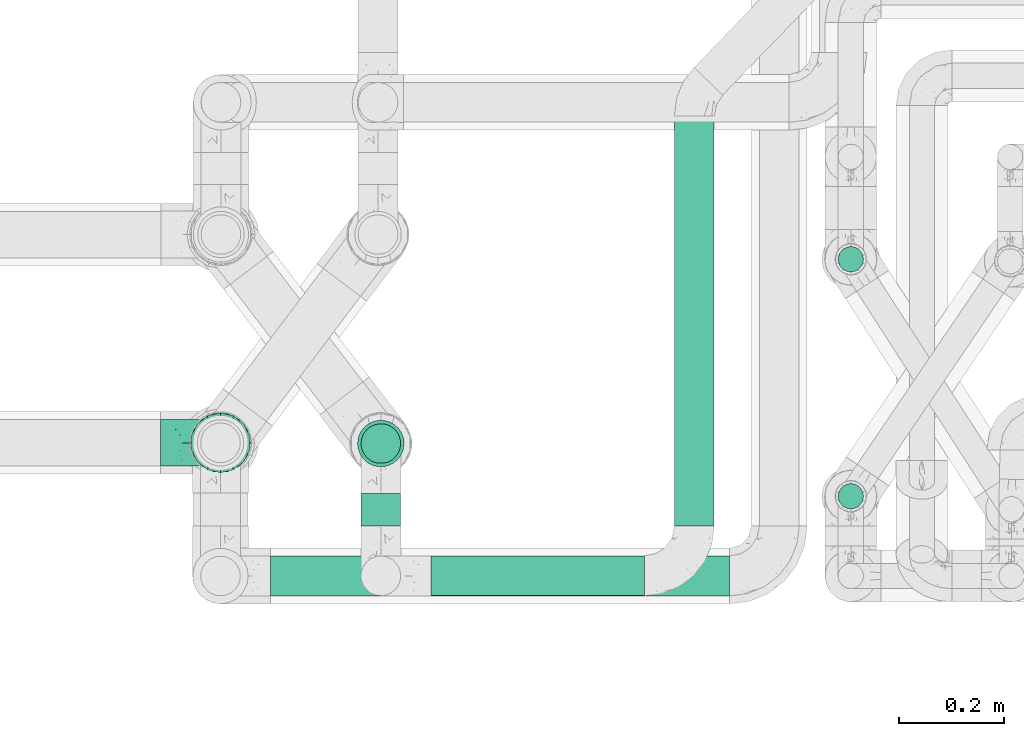
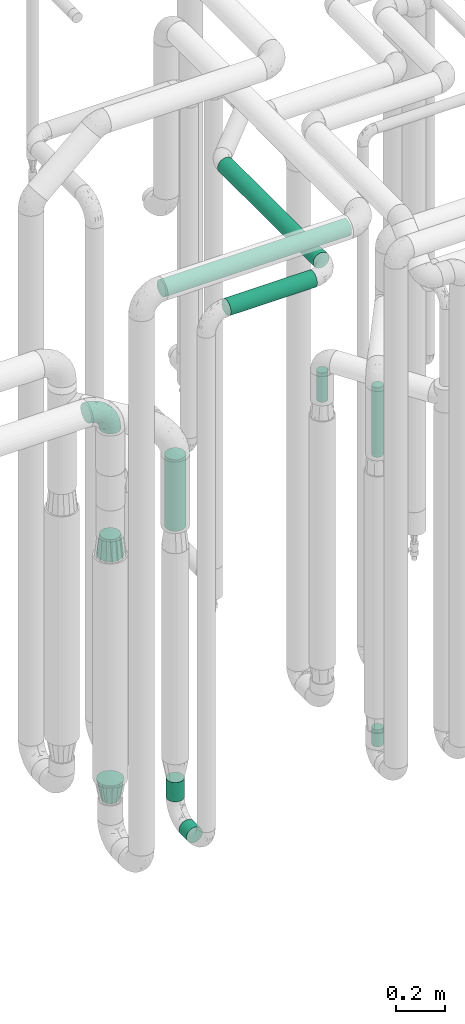
# One storey, part 659 of 827: 9 flow segments, 3 flow fittings.
"""IFC2X3 building model written with IfcOpenShell, lengths in millimetres."""

from ifc_helpers import new_model, entity, si_unit, converted_unit, derived_unit, direction, frame, origin, origin_2d_with_axis, place, context, subcontext, project, spatial, circle, extrude, faceted_brep, source, transform, mapped, material, type_object, type_shapes, element, save


model = new_model("IFC2X3")

# Units and contexts
model_context = context("Model", 3, precision=0.01, world=origin(), true_north=direction((6.12303176911189e-17, 1.0)))
body_context = subcontext(model_context, "Body", "Model", "MODEL_VIEW")
ifc_project = project(units=[si_unit("LENGTHUNIT", "METRE", prefix="MILLI"), si_unit("AREAUNIT", "SQUARE_METRE"), si_unit("VOLUMEUNIT", "CUBIC_METRE"), converted_unit("PLANEANGLEUNIT", "DEGREE", entity("IfcRatioMeasure", 0.0174532925199433), si_unit("PLANEANGLEUNIT", "RADIAN"), dimensions=[0, 0, 0, 0, 0, 0, 0]), si_unit("MASSUNIT", "GRAM", prefix="KILO"), derived_unit("MASSDENSITYUNIT", [(si_unit("MASSUNIT", "GRAM", prefix="KILO"), 1), (si_unit("LENGTHUNIT", "METRE"), -3)]), derived_unit("MOMENTOFINERTIAUNIT", [(si_unit("LENGTHUNIT", "METRE"), 4)]), si_unit("TIMEUNIT", "SECOND"), si_unit("FREQUENCYUNIT", "HERTZ"), si_unit("THERMODYNAMICTEMPERATUREUNIT", "DEGREE_CELSIUS"), derived_unit("THERMALTRANSMITTANCEUNIT", [(si_unit("MASSUNIT", "GRAM", prefix="KILO"), 1), (si_unit("THERMODYNAMICTEMPERATUREUNIT", "KELVIN"), -1), (si_unit("TIMEUNIT", "SECOND"), -3)]), derived_unit("VOLUMETRICFLOWRATEUNIT", [(si_unit("LENGTHUNIT", "METRE"), 3), (si_unit("TIMEUNIT", "SECOND"), -1)]), derived_unit("MASSFLOWRATEUNIT", [(si_unit("MASSUNIT", "GRAM", prefix="KILO"), 1), (si_unit("TIMEUNIT", "SECOND"), -1)]), derived_unit("ROTATIONALFREQUENCYUNIT", [(si_unit("TIMEUNIT", "SECOND"), -1)]), si_unit("ELECTRICCURRENTUNIT", "AMPERE"), si_unit("ELECTRICVOLTAGEUNIT", "VOLT"), si_unit("POWERUNIT", "WATT"), si_unit("FORCEUNIT", "NEWTON", prefix="KILO"), si_unit("ILLUMINANCEUNIT", "LUX"), si_unit("LUMINOUSFLUXUNIT", "LUMEN"), si_unit("LUMINOUSINTENSITYUNIT", "CANDELA"), derived_unit("USERDEFINED", [(si_unit("MASSUNIT", "GRAM", prefix="KILO"), -1), (si_unit("LENGTHUNIT", "METRE"), -2), (si_unit("TIMEUNIT", "SECOND"), 3), (si_unit("LUMINOUSFLUXUNIT", "LUMEN"), 1)]), derived_unit("LINEARVELOCITYUNIT", [(si_unit("LENGTHUNIT", "METRE"), 1), (si_unit("TIMEUNIT", "SECOND"), -1)]), si_unit("PRESSUREUNIT", "PASCAL"), derived_unit("USERDEFINED", [(si_unit("LENGTHUNIT", "METRE"), -2), (si_unit("MASSUNIT", "GRAM", prefix="KILO"), 1), (si_unit("TIMEUNIT", "SECOND"), -2)]), derived_unit("LINEARFORCEUNIT", [(si_unit("MASSUNIT", "GRAM", prefix="KILO"), 1), (si_unit("LENGTHUNIT", "METRE"), 1), (si_unit("TIMEUNIT", "SECOND"), -2), (si_unit("LENGTHUNIT", "METRE"), -1)]), derived_unit("PLANARFORCEUNIT", [(si_unit("MASSUNIT", "GRAM", prefix="KILO"), 1), (si_unit("LENGTHUNIT", "METRE"), 1), (si_unit("TIMEUNIT", "SECOND"), -2), (si_unit("LENGTHUNIT", "METRE"), -2)])], contexts=[model_context])

# Site, building, storey
site_placement = place(None, origin())
site = spatial("IfcSite", under=ifc_project, at=site_placement, CompositionType="ELEMENT")
building_placement = place(site_placement, origin())
building = spatial("IfcBuilding", under=site, at=building_placement, CompositionType="ELEMENT")
storey_placement = place(building_placement, frame((0.0, 0.0, 28200.0)))
storey = spatial("IfcBuildingStorey", under=building, at=storey_placement, Name="08", CompositionType="ELEMENT", Elevation=28200.0)

# Flow segments
pipe_segment_type = type_object("IfcPipeSegmentType", PredefinedType="NOTDEFINED")
flow_segment_1_placement = place(storey_placement, frame((46667.19, 13762.91, 457.0)))
element("IfcFlowSegment", 1, at=flow_segment_1_placement, inside=storey, type_object=pipe_segment_type, context=body_context, shape_type="SweptSolid", body=[
    extrude(circle(Radius=24.0, at=origin_2d_with_axis()), frame((25.6, 25.6, 0.0)), (0.0, 0.0, 1.0), 84.021536088702),
])
flow_segment_2_placement = place(storey_placement, frame((45759.1, 13731.98, 310.65)))
element("IfcFlowSegment", 2, at=flow_segment_2_placement, inside=storey, type_object=pipe_segment_type, context=body_context, shape_type="SweptSolid", body=[
    extrude(circle(Radius=37.75, at=origin_2d_with_axis()), frame((39.35, 0.0, 39.35), z_axis=(0.0, 1.0, 0.0), x_axis=(1.0, 0.0, 0.0)), (0.0, 0.0, 1.0), 61.8355247890421),
])
flow_segment_3_placement = place(storey_placement, frame((45759.1, 13849.47, 445.0)))
element("IfcFlowSegment", 3, at=flow_segment_3_placement, inside=storey, type_object=pipe_segment_type, context=body_context, shape_type="SweptSolid", body=[
    extrude(circle(Radius=37.75, at=origin_2d_with_axis()), frame((39.35, 39.35, 0.0)), (0.0, 0.0, 1.0), 96.0215360886949),
])
flow_segment_4_placement = place(storey_placement, frame((46667.19, 14213.93, 1897.5)))
element("IfcFlowSegment", 4, at=flow_segment_4_placement, inside=storey, type_object=pipe_segment_type, context=body_context, shape_type="SweptSolid", body=[
    extrude(circle(Radius=24.0, at=origin_2d_with_axis()), frame((25.6, 25.6, 0.0)), (0.0, 0.0, 1.0), 145.61232988612),
])
flow_segment_5_placement = place(storey_placement, frame((46667.19, 13762.91, 1897.5)))
element("IfcFlowSegment", 5, at=flow_segment_5_placement, inside=storey, type_object=pipe_segment_type, context=body_context, shape_type="SweptSolid", body=[
    extrude(circle(Radius=24.0, at=origin_2d_with_axis()), frame((25.6, 25.6, 0.0)), (0.0, 0.0, 1.0), 345.500000000008),
])
flow_segment_6_placement = place(storey_placement, frame((45893.44, 13597.63, 2960.65)))
element("IfcFlowSegment", 6, at=flow_segment_6_placement, inside=storey, type_object=pipe_segment_type, context=body_context, shape_type="SweptSolid", body=[
    extrude(circle(Radius=37.75, at=origin_2d_with_axis()), frame((0.0, 39.35, 39.35), z_axis=(1.0, 0.0, 0.0), x_axis=(0.0, -1.0, 0.0)), (0.0, 0.0, 1.0), 406.591830258008),
])
flow_segment_7_placement = place(storey_placement, frame((46355.69, 13731.98, 2960.65)))
element("IfcFlowSegment", 7, at=flow_segment_7_placement, inside=storey, type_object=pipe_segment_type, context=body_context, shape_type="SweptSolid", body=[
    extrude(circle(Radius=37.75, at=origin_2d_with_axis()), frame((39.35, 0.0, 39.35), z_axis=(0.0, 1.0, 0.0), x_axis=(1.0, 0.0, 0.0)), (0.0, 0.0, 1.0), 780.21688691767),
])
flow_segment_8_placement = place(storey_placement, frame((45588.28, 13597.49, 3160.7)))
element("IfcFlowSegment", 8, at=flow_segment_8_placement, inside=storey, type_object=pipe_segment_type, context=body_context, shape_type="SweptSolid", body=[
    extrude(circle(Radius=37.75, at=origin_2d_with_axis()), frame((0.0, 39.35, 39.35), z_axis=(1.0, 0.0, 0.0), x_axis=(0.0, 1.0, 0.0)), (0.0, 0.0, 1.0), 873.494530065555),
])
flow_segment_9_placement = place(storey_placement, frame((45752.6, 13842.97, 1795.2)))
element("IfcFlowSegment", 9, at=flow_segment_9_placement, inside=storey, type_object=pipe_segment_type, context=body_context, shape_type="SweptSolid", body=[
    extrude(circle(Radius=44.25, at=origin_2d_with_axis()), frame((45.85, 45.85, 0.0)), (0.0, 0.0, 1.0), 355.800000000036),
])

# Flow fittings
ifc_material = material()
pipe_fitting_type_1 = type_object("IfcPipeFittingType", Name="ADSK_1", PredefinedType="NOTDEFINED", material=ifc_material)
shared_shape_1 = source(origin(), body_context, "Body", "Brep", [
    faceted_brep([(-114.0, 22.22, -38.49), (-114.0, 11.5, -42.94), (-114.0, 0.0, -44.45), (-114.0, -11.5, -42.94), (-114.0, -22.23, -38.49), (-114.0, -31.43, -31.43), (-114.0, -38.49, -22.23), (-114.0, -42.94, -11.5), (-114.0, -44.45, 0.0), (-114.0, -42.94, 11.5), (-114.0, -38.49, 22.22), (-114.0, -31.43, 31.43), (-114.0, -22.23, 38.49), (-114.0, -11.5, 42.94), (-114.0, 0.0, 44.45), (-114.0, 11.5, 42.94), (-114.0, 22.22, 38.49), (-114.0, 31.43, 31.43), (-114.0, 38.49, 22.22), (-114.0, 42.94, 11.5), (-114.0, 44.45, 0.0), (-114.0, 42.94, -11.5), (-114.0, 38.49, -22.23), (-114.0, 31.43, -31.43), (0.0, 114.0, -44.45), (-11.5, 114.0, -42.94), (-22.22, 114.0, -38.49), (-31.43, 114.0, -31.43), (-38.49, 114.0, -22.23), (-42.94, 114.0, -11.5), (-44.45, 114.0, 0.0), (-42.94, 114.0, 11.5), (-38.49, 114.0, 22.22), (-31.43, 114.0, 31.43), (-22.22, 114.0, 38.49), (-11.5, 114.0, 42.94), (0.0, 114.0, 44.45), (11.5, 114.0, 42.94), (22.23, 114.0, 38.49), (31.43, 114.0, 31.43), (38.49, 114.0, 22.22), (42.94, 114.0, 11.5), (44.45, 114.0, 0.0), (42.94, 114.0, -11.5), (38.49, 114.0, -22.23), (31.43, 114.0, -31.43), (22.23, 114.0, -38.49), (11.5, 114.0, -42.94), (-24.5, -15.82, 8.24), (-7.18, -2.06, 7.97), (-13.53, -4.79, 15.72), (-92.03, -41.56, 0.0), (-77.08, -37.56, 14.57), (23.74, 74.96, 33.55), (-72.99, -39.05, 0.0), (-84.56, -15.6, 40.23), (-47.88, -6.37, 37.83), (-59.8, 2.77, 43.37), (-84.46, -33.54, 25.41), (16.69, 49.28, 31.02), (6.37, 47.88, 37.83), (3.35, 25.47, 29.77), (-47.43, 81.55, 19.51), (-74.96, -23.74, 33.55), (-46.77, -27.89, 11.23), (-53.88, -31.14, 0.0), (-87.05, 38.52, 28.81), (-63.44, 55.78, 24.79), (-93.24, 43.37, 18.58), (-16.67, 16.67, 37.64), (-25.47, -3.35, 29.77), (-17.2, 97.7, 41.53), (-7.42, 85.54, 44.3), (-67.09, 46.29, 31.23), (-18.08, 42.1, 44.06), (-32.93, 14.9, 42.17), (-11.54, 34.94, 41.69), (-95.7, 27.79, 36.14), (-88.55, -4.92, 43.79), (-2.77, 59.8, 43.37), (-87.65, 48.44, 9.87), (-81.01, 8.37, 44.32), (-37.63, 90.26, 28.6), (-51.29, 61.56, 30.59), (-29.32, 87.72, 36.52), (23.49, 49.5, 23.28), (8.19, 20.11, 19.18), (-70.06, 58.9, 9.01), (-87.38, 49.74, 0.0), (-88.15, 18.57, 41.8), (-7.96, 6.22, 24.33), (33.54, 84.46, 25.41), (37.56, 77.08, 14.57), (-58.37, 34.98, 40.92), (-62.38, 23.02, 43.45), (24.15, 39.93, 12.16), (31.14, 53.88, 0.0), (-58.13, 14.61, 44.45), (-37.17, 26.09, 44.37), (4.92, 88.55, 43.79), (-34.77, -23.22, 0.0), (-49.5, -23.49, 23.28), (41.56, 92.03, 0.0), (-57.83, 66.03, 19.12), (-71.84, 54.46, 17.06), (-46.46, 94.23, 8.51), (-49.74, 87.38, 0.0), (-38.96, 59.98, 38.88), (-55.29, 46.95, 36.83), (-64.82, 64.82, 0.0), (-55.88, 73.75, 10.01), (15.6, 84.56, 40.23), (-21.6, 76.38, 42.11), (-49.04, -15.53, 31.95), (-19.97, 55.59, 44.33), (-73.61, 33.95, 37.2), (-31.05, 58.14, 42.19), (-41.3, 41.3, 43.02), (-27.36, -11.22, 22.61), (9.28, 15.84, 8.73), (23.22, 34.77, 0.0), (39.05, 72.99, 0.0), (-1.96, 1.96, 0.0), (10.63, 18.37, 0.0), (-18.37, -10.63, 0.0), (-97.7, 17.2, -41.53), (9.28, 15.84, -8.73), (-13.53, -4.79, -15.72), (8.19, 20.11, -19.18), (-85.54, 7.42, -44.3), (-8.37, 81.01, -44.32), (-90.26, 37.63, -28.6), (-87.72, 29.32, -36.52), (-27.79, 95.7, -36.14), (-38.52, 87.05, -28.81), (-94.23, 46.46, -8.51), (-84.56, -15.6, -40.23), (-73.75, 55.88, -10.01), (-10.19, -4.86, -7.51), (-76.38, 21.6, -42.11), (-59.98, 38.96, -38.88), (-49.28, -16.69, -31.02), (-47.88, -6.37, -37.83), (-25.47, -3.35, -29.77), (-34.98, 58.37, -40.92), (-46.95, 55.29, -36.83), (-77.08, -37.56, -14.57), (-18.57, 88.15, -41.8), (-23.02, 62.38, -43.45), (-55.78, 63.44, -24.79), (-43.37, 93.24, -18.58), (-84.46, -33.54, -25.41), (-33.95, 73.61, -37.2), (-46.29, 67.09, -31.23), (-74.96, -23.74, -33.55), (-48.44, 87.65, -9.87), (-45.44, -27.06, -11.87), (-88.55, -4.92, -43.79), (-49.5, -23.49, -23.28), (-14.61, 58.13, -44.45), (-26.09, 37.17, -44.37), (15.6, 84.56, -40.23), (6.37, 47.88, -37.83), (-2.77, 59.8, -43.37), (-81.55, 47.43, -19.51), (33.54, 84.46, -25.41), (23.49, 49.5, -23.28), (23.74, 74.96, -33.55), (-42.1, 18.08, -44.06), (-14.9, 32.93, -42.17), (-34.94, 11.54, -41.69), (-61.56, 51.29, -30.59), (-27.36, -11.22, -22.61), (37.56, 77.08, -14.57), (4.92, 88.55, -43.79), (-59.8, 2.77, -43.37), (-66.03, 57.83, -19.12), (-54.46, 71.84, -17.06), (-55.59, 19.97, -44.33), (-58.9, 70.06, -9.01), (24.15, 39.93, -12.16), (15.53, 49.04, -31.95), (-58.14, 31.05, -42.19), (-41.3, 41.3, -43.02), (-16.67, 16.67, -37.64), (3.35, 25.47, -29.77), (-7.96, 6.22, -24.33), (-26.36, -16.33, -11.05)], [[[0, 1, 2, 3, 4, 5, 6, 7, 8, 9, 10, 11, 12, 13, 14, 15, 16, 17, 18, 19, 20, 21, 22, 23]], [[24, 25, 26, 27, 28, 29, 30, 31, 32, 33, 34, 35, 36, 37, 38, 39, 40, 41, 42, 43, 44, 45, 46, 47]], [[48, 49, 50]], [[51, 52, 9]], [[53, 39, 38]], [[9, 52, 10]], [[54, 52, 51]], [[55, 56, 57]], [[11, 10, 58]], [[59, 60, 61]], [[32, 31, 62]], [[63, 12, 11]], [[63, 55, 12]], [[64, 52, 65]], [[66, 67, 68]], [[69, 56, 70]], [[35, 71, 72]], [[67, 66, 73]], [[74, 75, 76]], [[16, 77, 17]], [[13, 78, 14]], [[76, 79, 74]], [[68, 80, 19]], [[18, 17, 66]], [[14, 78, 81]], [[20, 19, 80]], [[82, 83, 84]], [[85, 61, 86]], [[87, 88, 80]], [[18, 68, 19]], [[15, 89, 16]], [[14, 81, 15]], [[70, 90, 61]], [[17, 77, 66]], [[91, 85, 92]], [[93, 89, 94]], [[95, 96, 92]], [[84, 71, 34]], [[94, 97, 98]], [[37, 36, 99]], [[40, 39, 91]], [[40, 92, 41]], [[65, 100, 64]], [[91, 92, 40]], [[58, 101, 63]], [[92, 102, 41]], [[92, 85, 95]], [[67, 103, 104]], [[34, 33, 84]], [[105, 62, 31]], [[52, 58, 10]], [[106, 105, 30]], [[93, 107, 108]], [[106, 109, 110]], [[53, 111, 60]], [[84, 112, 71]], [[84, 107, 112]], [[33, 82, 84]], [[12, 55, 13]], [[113, 56, 63]], [[111, 38, 37]], [[34, 71, 35]], [[36, 35, 72]], [[112, 114, 72]], [[110, 105, 106]], [[111, 53, 38]], [[115, 108, 73]], [[89, 15, 81]], [[104, 87, 80]], [[110, 87, 103]], [[33, 32, 82]], [[116, 107, 117]], [[112, 116, 114]], [[99, 72, 79]], [[56, 55, 63]], [[78, 55, 57]], [[101, 118, 113]], [[56, 69, 75]], [[99, 111, 37]], [[79, 76, 60]], [[79, 60, 111]], [[60, 69, 61]], [[101, 58, 52]], [[63, 11, 58]], [[39, 53, 91]], [[85, 91, 53]], [[94, 89, 81]], [[77, 89, 115]], [[84, 83, 107]], [[93, 108, 115]], [[98, 114, 117]], [[79, 72, 114]], [[98, 117, 94]], [[98, 57, 75]], [[32, 62, 82]], [[83, 82, 62]], [[70, 113, 118]], [[61, 85, 59]], [[48, 64, 100]], [[95, 119, 120]], [[69, 70, 61]], [[70, 118, 90]], [[72, 99, 36]], [[111, 99, 79]], [[55, 78, 13]], [[81, 78, 57]], [[94, 81, 97]], [[93, 94, 117]], [[66, 68, 18]], [[80, 68, 104]], [[103, 87, 104]], [[80, 88, 20]], [[50, 49, 119]], [[95, 85, 86]], [[119, 95, 86]], [[121, 92, 96]], [[50, 119, 86]], [[119, 122, 123, 120]], [[110, 109, 87]], [[88, 87, 109]], [[62, 105, 110]], [[30, 105, 31]], [[81, 57, 97]], [[57, 98, 97]], [[107, 93, 117]], [[89, 93, 115]], [[107, 83, 108]], [[73, 108, 83]], [[67, 73, 83]], [[115, 73, 66]], [[103, 83, 62]], [[67, 104, 68]], [[83, 103, 67]], [[110, 103, 62]], [[89, 77, 16]], [[66, 77, 115]], [[56, 75, 57]], [[76, 75, 69]], [[60, 76, 69]], [[79, 114, 74]], [[114, 98, 74]], [[75, 74, 98]], [[9, 8, 51]], [[102, 92, 121]], [[102, 42, 41]], [[72, 71, 112]], [[52, 54, 65]], [[64, 48, 118]], [[101, 52, 64]], [[124, 122, 49]], [[118, 48, 50]], [[49, 48, 124]], [[119, 49, 122]], [[48, 100, 124]], [[114, 116, 117]], [[112, 107, 116]], [[101, 113, 63]], [[70, 56, 113]], [[64, 118, 101]], [[90, 50, 86]], [[50, 90, 118]], [[61, 90, 86]], [[85, 53, 59]], [[60, 59, 53]], [[95, 120, 96]], [[125, 1, 0]], [[126, 127, 128]], [[2, 1, 129]], [[24, 130, 25]], [[131, 132, 23]], [[27, 133, 134]], [[88, 135, 20]], [[136, 4, 3]], [[88, 109, 137]], [[138, 122, 124]], [[139, 132, 140]], [[141, 142, 143]], [[144, 140, 145]], [[125, 132, 139]], [[6, 146, 7]], [[144, 147, 148]], [[146, 51, 7]], [[134, 149, 150]], [[146, 6, 151]], [[152, 145, 153]], [[154, 4, 136]], [[154, 136, 142]], [[150, 155, 29]], [[43, 42, 102]], [[65, 146, 156]], [[0, 23, 132]], [[157, 3, 2]], [[146, 151, 158]], [[148, 159, 160]], [[161, 162, 163]], [[135, 164, 21]], [[165, 166, 167]], [[168, 169, 170]], [[147, 25, 130]], [[171, 132, 131]], [[155, 30, 29]], [[172, 141, 143]], [[134, 28, 27]], [[149, 134, 153]], [[173, 165, 44]], [[26, 25, 147]], [[22, 21, 164]], [[24, 174, 130]], [[133, 27, 26]], [[170, 175, 168]], [[24, 47, 174]], [[45, 167, 46]], [[28, 150, 29]], [[1, 125, 129]], [[156, 100, 65]], [[165, 45, 44]], [[161, 46, 167]], [[173, 44, 43]], [[6, 5, 151]], [[173, 102, 121]], [[137, 135, 88]], [[46, 161, 47]], [[102, 173, 43]], [[149, 176, 177]], [[172, 158, 141]], [[139, 178, 129]], [[154, 5, 4]], [[156, 146, 158]], [[106, 155, 179]], [[173, 96, 180]], [[181, 162, 167]], [[177, 179, 155]], [[137, 179, 176]], [[23, 22, 131]], [[182, 140, 183]], [[139, 182, 178]], [[157, 129, 175]], [[157, 136, 3]], [[175, 170, 142]], [[175, 142, 136]], [[142, 184, 143]], [[162, 161, 167]], [[174, 161, 163]], [[181, 166, 185]], [[162, 184, 169]], [[5, 154, 151]], [[158, 151, 154]], [[166, 165, 173]], [[167, 45, 165]], [[148, 147, 130]], [[133, 147, 152]], [[132, 171, 140]], [[144, 145, 152]], [[160, 178, 183]], [[175, 129, 178]], [[160, 183, 148]], [[160, 163, 169]], [[22, 164, 131]], [[171, 131, 164]], [[162, 185, 184]], [[186, 127, 172]], [[185, 128, 186]], [[156, 187, 100]], [[185, 166, 128]], [[143, 184, 185]], [[129, 157, 2]], [[136, 157, 175]], [[161, 174, 47]], [[130, 174, 163]], [[148, 130, 159]], [[144, 148, 183]], [[134, 150, 28]], [[155, 150, 177]], [[176, 179, 177]], [[155, 106, 30]], [[166, 180, 128]], [[128, 180, 126]], [[173, 180, 166]], [[126, 120, 123, 122]], [[120, 126, 180]], [[122, 138, 126]], [[137, 109, 179]], [[106, 179, 109]], [[164, 135, 137]], [[20, 135, 21]], [[130, 163, 159]], [[163, 160, 159]], [[140, 144, 183]], [[147, 144, 152]], [[140, 171, 145]], [[153, 145, 171]], [[149, 153, 171]], [[152, 153, 134]], [[176, 171, 164]], [[149, 177, 150]], [[171, 176, 149]], [[137, 176, 164]], [[147, 133, 26]], [[134, 133, 152]], [[162, 169, 163]], [[170, 169, 184]], [[142, 170, 184]], [[175, 178, 168]], [[178, 160, 168]], [[169, 168, 160]], [[51, 146, 54]], [[51, 8, 7]], [[132, 125, 0]], [[129, 125, 139]], [[156, 158, 172]], [[65, 54, 146]], [[178, 182, 183]], [[139, 140, 182]], [[158, 154, 141]], [[142, 141, 154]], [[186, 172, 143]], [[172, 127, 187]], [[185, 186, 143]], [[127, 186, 128]], [[187, 127, 138]], [[124, 100, 187]], [[126, 138, 127]], [[187, 138, 124]], [[172, 187, 156]], [[166, 181, 167]], [[185, 162, 181]], [[96, 173, 121]], [[96, 120, 180]]]),
])
type_shapes(pipe_fitting_type_1, [shared_shape_1])
flow_fitting_1_placement = place(storey_placement, frame((45493.28, 13890.17, 2500.0), z_axis=(0.0, -1.0, 0.0), x_axis=(0.0, 0.0, 1.0)))
element("IfcFlowFitting", 10, at=flow_fitting_1_placement, inside=storey, type_object=pipe_fitting_type_1, material=ifc_material, Name="ADSK_1", ObjectType="ADSK_1", context=body_context, shape_type="MappedRepresentation", body=[
    mapped(shared_shape_1, transform((0.0, 0.0, 0.0), scale=1.0)),
])
pipe_fitting_type_2 = type_object("IfcPipeFittingType", Name="ADSK_1", PredefinedType="NOTDEFINED", material=ifc_material)
shared_shape_2 = source(origin(), body_context, "Body", "Brep", [
    faceted_brep([(102.0, -30.36, 30.36), (102.0, -38.49, 22.23), (102.0, -41.47, 11.11), (102.0, -44.45, 0.0), (102.0, -41.47, -11.11), (102.0, -38.49, -22.22), (102.0, -30.36, -30.36), (102.0, -22.23, -38.49), (102.0, -11.11, -41.47), (102.0, 0.0, -44.45), (102.0, 11.11, -41.47), (102.0, 22.22, -38.49), (102.0, 30.36, -30.36), (102.0, 38.49, -22.22), (102.0, 41.47, -11.11), (102.0, 44.45, 0.0), (102.0, 41.47, 11.11), (102.0, 38.49, 22.23), (102.0, 30.36, 30.36), (102.0, 22.22, 38.49), (102.0, 11.11, 41.47), (102.0, 0.0, 44.45), (102.0, -11.11, 41.47), (102.0, -22.23, 38.49), (0.0, 24.17, 50.2), (0.0, 35.63, 44.68), (0.0, 43.56, 34.74), (0.0, 51.49, 24.8), (0.0, 54.32, 12.4), (0.0, 57.15, 0.0), (0.0, 54.32, -12.4), (0.0, 51.49, -24.8), (0.0, 43.56, -34.74), (0.0, 35.63, -44.68), (0.0, 24.17, -50.2), (0.0, 12.72, -55.72), (0.0, 0.0, -55.72), (0.0, -12.72, -55.72), (0.0, -24.17, -50.2), (0.0, -35.63, -44.68), (0.0, -43.56, -34.74), (0.0, -51.49, -24.8), (0.0, -54.32, -12.4), (0.0, -57.15, 0.0), (0.0, -54.32, 12.4), (0.0, -51.49, 24.8), (0.0, -43.56, 34.74), (0.0, -35.63, 44.68), (0.0, -24.17, 50.2), (0.0, -12.72, 55.72), (0.0, 0.0, 55.72), (0.0, 12.72, 55.72)], [[[0, 1, 2, 3, 4, 5, 6, 7, 8, 9, 10, 11, 12, 13, 14, 15, 16, 17, 18, 19, 20, 21, 22, 23]], [[24, 25, 26, 27, 28, 29, 30, 31, 32, 33, 34, 35, 36, 37, 38, 39, 40, 41, 42, 43, 44, 45, 46, 47, 48, 49, 50, 51]], [[14, 31, 30]], [[42, 3, 43]], [[32, 31, 13]], [[13, 31, 14]], [[34, 10, 35]], [[3, 42, 4]], [[12, 11, 33]], [[9, 37, 36, 35]], [[7, 39, 38]], [[39, 7, 6]], [[38, 8, 7]], [[34, 33, 11]], [[10, 9, 35]], [[40, 5, 41]], [[12, 33, 32]], [[15, 30, 29]], [[38, 37, 8]], [[15, 14, 30]], [[41, 5, 4]], [[5, 40, 6]], [[13, 12, 32]], [[10, 34, 11]], [[37, 9, 8]], [[40, 39, 6]], [[42, 41, 4]], [[2, 45, 44]], [[28, 15, 29]], [[46, 45, 1]], [[1, 45, 2]], [[48, 22, 49]], [[15, 28, 16]], [[0, 23, 47]], [[21, 51, 50, 49]], [[19, 25, 24]], [[25, 19, 18]], [[24, 20, 19]], [[48, 47, 23]], [[22, 21, 49]], [[26, 17, 27]], [[0, 47, 46]], [[3, 44, 43]], [[24, 51, 20]], [[3, 2, 44]], [[27, 17, 16]], [[17, 26, 18]], [[1, 0, 46]], [[22, 48, 23]], [[51, 21, 20]], [[26, 25, 18]], [[28, 27, 16]]]),
])
type_shapes(pipe_fitting_type_2, [shared_shape_2])
flow_fitting_2_placement = place(storey_placement, frame((45493.28, 13890.17, 1758.0), z_axis=(1.0, 0.0, 0.0), x_axis=(0.0, 0.0, 1.0)))
element("IfcFlowFitting", 11, at=flow_fitting_2_placement, inside=storey, type_object=pipe_fitting_type_2, material=ifc_material, Name="ADSK_1", ObjectType="ADSK_1", context=body_context, shape_type="MappedRepresentation", body=[
    mapped(shared_shape_2, transform((0.0, 0.0, 0.0), scale=1.0)),
])
pipe_fitting_type_3 = type_object("IfcPipeFittingType", Name="ADSK_1", PredefinedType="NOTDEFINED", material=ifc_material)
shared_shape_3 = source(origin(), body_context, "Body", "Brep", [
    faceted_brep([(102.0, -57.15, 0.0), (102.0, -54.32, -12.4), (102.0, -51.49, -24.8), (102.0, -43.56, -34.74), (102.0, -35.63, -44.68), (102.0, -24.17, -50.2), (102.0, -12.72, -55.72), (102.0, 0.0, -55.72), (102.0, 12.72, -55.72), (102.0, 24.17, -50.2), (102.0, 35.63, -44.68), (102.0, 43.56, -34.74), (102.0, 51.49, -24.8), (102.0, 54.32, -12.4), (102.0, 57.15, 0.0), (102.0, 54.32, 12.4), (102.0, 51.49, 24.8), (102.0, 43.56, 34.74), (102.0, 35.63, 44.68), (102.0, 24.17, 50.2), (102.0, 12.72, 55.72), (102.0, 0.0, 55.72), (102.0, -12.72, 55.72), (102.0, -24.17, 50.2), (102.0, -35.63, 44.68), (102.0, -43.56, 34.74), (102.0, -51.49, 24.8), (102.0, -54.32, 12.4), (0.0, 38.05, 0.0), (0.0, 35.5, -9.51), (0.0, 32.95, -19.02), (0.0, 25.99, -25.99), (0.0, 19.02, -32.95), (0.0, 9.51, -35.5), (0.0, 0.0, -38.05), (0.0, -9.51, -35.5), (0.0, -19.02, -32.95), (0.0, -25.99, -25.99), (0.0, -32.95, -19.02), (0.0, -35.5, -9.51), (0.0, -38.05, 0.0), (0.0, -35.5, 9.51), (0.0, -32.95, 19.03), (0.0, -25.99, 25.99), (0.0, -19.03, 32.95), (0.0, -9.51, 35.5), (0.0, 0.0, 38.05), (0.0, 9.51, 35.5), (0.0, 19.03, 32.95), (0.0, 25.99, 25.99), (0.0, 32.95, 19.03), (0.0, 35.5, 9.51)], [[[0, 1, 2, 3, 4, 5, 6, 7, 8, 9, 10, 11, 12, 13, 14, 15, 16, 17, 18, 19, 20, 21, 22, 23, 24, 25, 26, 27]], [[28, 29, 30, 31, 32, 33, 34, 35, 36, 37, 38, 39, 40, 41, 42, 43, 44, 45, 46, 47, 48, 49, 50, 51]], [[38, 2, 39]], [[11, 10, 31]], [[8, 34, 33]], [[3, 2, 38]], [[40, 39, 1]], [[28, 13, 29]], [[40, 1, 0]], [[32, 10, 9]], [[34, 8, 7, 6]], [[37, 36, 4]], [[39, 2, 1]], [[33, 32, 9]], [[38, 37, 3]], [[37, 4, 3]], [[5, 4, 36]], [[13, 28, 14]], [[10, 32, 31]], [[8, 33, 9]], [[35, 5, 36]], [[30, 11, 31]], [[29, 12, 30]], [[5, 35, 6]], [[35, 34, 6]], [[11, 30, 12]], [[13, 12, 29]], [[50, 16, 51]], [[25, 24, 43]], [[22, 46, 45]], [[17, 16, 50]], [[28, 51, 15]], [[40, 27, 41]], [[28, 15, 14]], [[44, 24, 23]], [[46, 22, 21, 20]], [[49, 48, 18]], [[51, 16, 15]], [[45, 44, 23]], [[50, 49, 17]], [[49, 18, 17]], [[19, 18, 48]], [[27, 40, 0]], [[24, 44, 43]], [[22, 45, 23]], [[47, 19, 48]], [[42, 25, 43]], [[41, 26, 42]], [[19, 47, 20]], [[47, 46, 20]], [[25, 42, 26]], [[27, 26, 41]]]),
])
type_shapes(pipe_fitting_type_3, [shared_shape_3])
flow_fitting_3_placement = place(storey_placement, frame((45493.28, 13890.17, 541.02), z_axis=(0.0, -1.0, 0.0), x_axis=(0.0, 0.0, 1.0)))
element("IfcFlowFitting", 12, at=flow_fitting_3_placement, inside=storey, type_object=pipe_fitting_type_3, material=ifc_material, Name="ADSK_1", ObjectType="ADSK_1", context=body_context, shape_type="MappedRepresentation", body=[
    mapped(shared_shape_3, transform((0.0, 0.0, 0.0), scale=1.0)),
])

save(model, "model.ifc")
